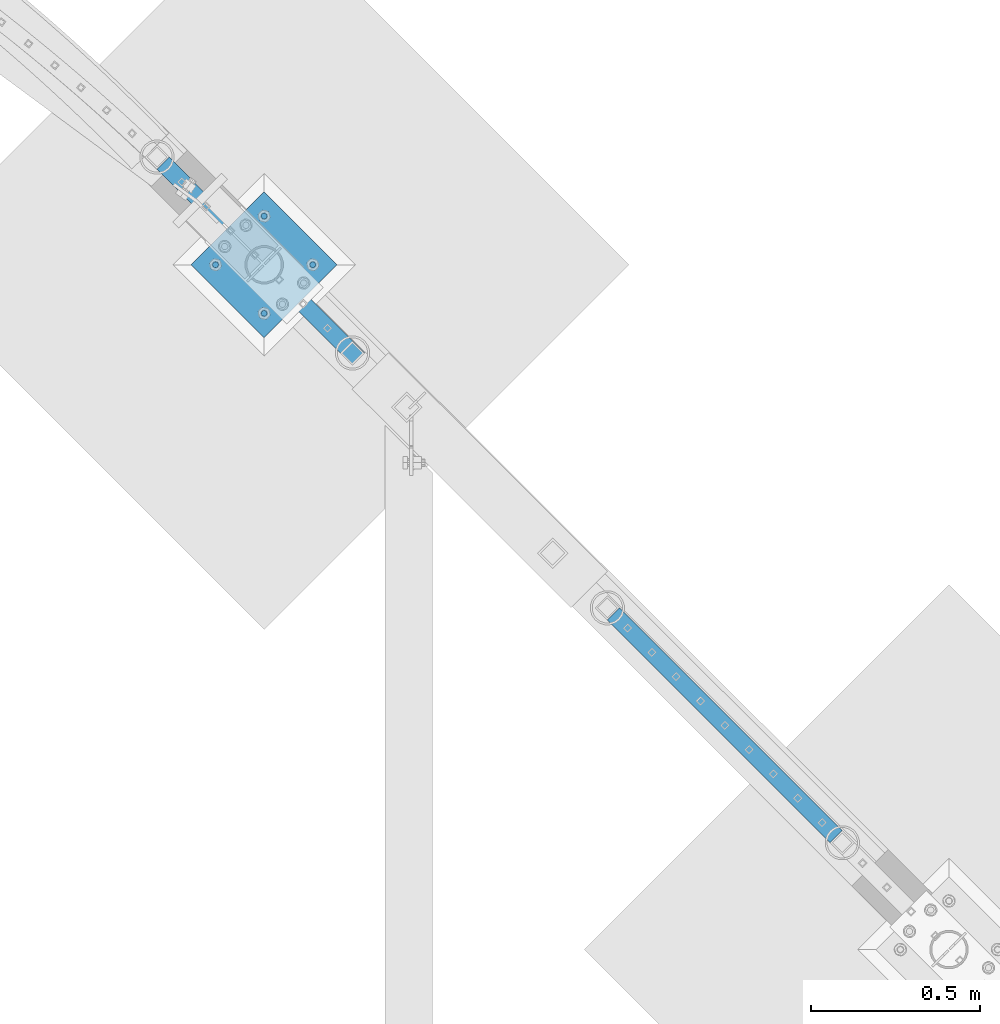
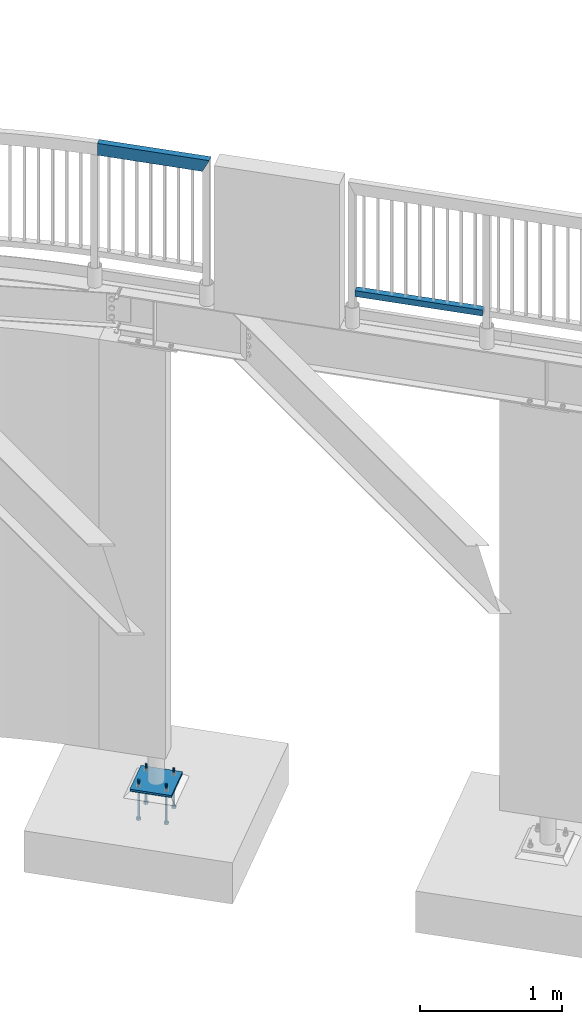
# One storey, part 452 of 975: 8 beams.
"""IFC2X3 building model written with IfcOpenShell, lengths in millimetres."""

from ifc_helpers import new_model, si_unit, frame, origin_with_axes, place, context, subcontext, project, spatial, faceted_brep, material, type_object, element, save


model = new_model("IFC2X3")

# Units and contexts
model_context = context("Model", 3, precision=1e-05, world=origin_with_axes())
body_context = subcontext(model_context, "Body", "Model", "MODEL_VIEW")
ifc_project = project(units=[si_unit("LENGTHUNIT", "METRE", prefix="MILLI"), si_unit("AREAUNIT", "SQUARE_METRE"), si_unit("VOLUMEUNIT", "CUBIC_METRE"), si_unit("MASSUNIT", "GRAM", prefix="KILO"), si_unit("TIMEUNIT", "SECOND"), si_unit("PLANEANGLEUNIT", "RADIAN"), si_unit("SOLIDANGLEUNIT", "STERADIAN"), si_unit("THERMODYNAMICTEMPERATUREUNIT", "DEGREE_CELSIUS"), si_unit("LUMINOUSINTENSITYUNIT", "LUMEN")], contexts=[model_context])

# Site, building, storey
site_placement = place(None, origin_with_axes())
site = spatial("IfcSite", under=ifc_project, at=site_placement, CompositionType="ELEMENT")
building_placement = place(site_placement, origin_with_axes())
building = spatial("IfcBuilding", under=site, at=building_placement, Name="Undefined", CompositionType="ELEMENT")
storey_placement = place(building_placement, origin_with_axes())
storey = spatial("IfcBuildingStorey", under=building, at=storey_placement, Name="Undefined", CompositionType="ELEMENT", Elevation=0.0)

# Beams
ifc_material_1 = material()
beam_type_1 = type_object("IfcBeamType", Name="HSS2X2X.188_TUBES", PredefinedType="NOTDEFINED")
beam_1_placement = place(storey_placement, frame((22439.8337126223, 26194.8377274758, 4229.09999851784), z_axis=(-0.70706737708869, -0.707146183088702, 0.0), x_axis=(-0.707146183088701, 0.707067377088692, 1.9999997400896e-09)))
element("IfcBeam", 1, at=beam_1_placement, inside=storey, type_object=beam_type_1, material=ifc_material_1, Name="HANDRAIL", ObjectType="HSS2X2X.188_TUBES", context=body_context, shape_type="Brep", body=[
    faceted_brep([(25.3980770247526, 20.6375000000007, -20.6375000000553), (25.3981117216435, -20.6374999999998, -20.6375000000553), (956.733660036939, -20.6374999999807, -20.6375000008629), (956.733659954443, 20.6375000000198, -20.6375000008702), (25.4004117403574, -20.6374999999998, 20.6375000000116), (956.735960055649, -20.6374999999807, 20.637499999204), (25.4003770434665, 20.6375000000007, 20.6375000000116), (956.735959973155, 20.6375000000198, 20.6374999991967), (25.3978076344952, 25.4000000000005, -25.4000000000669), (25.4006384267554, 25.4000000000005, 25.4000000000087), (956.736225350408, 25.4000000000196, 25.3999999992011), (956.733394558152, 25.4000000000206, -25.4000000008746), (25.4006811306149, -25.3999999999987, 25.4000000000233), (956.736225451941, -25.3999999999796, 25.3999999992084), (25.3978503383546, -25.3999999999987, -25.4000000000597), (956.733394659682, -25.3999999999796, -25.4000000008673)], [[[0, 1, 2, 3]], [[1, 4, 5, 2]], [[4, 6, 7, 5]], [[6, 0, 3, 7]], [[8, 9, 10, 11]], [[9, 12, 13, 10]], [[12, 14, 15, 13]], [[14, 8, 11, 15]], [[13, 15, 11, 10], [5, 7, 3, 2]], [[14, 12, 9, 8], [6, 4, 1, 0]]]),
])
beam_type_2 = type_object("IfcBeamType", Name="HSS2X4X.188_TUBES", PredefinedType="NOTDEFINED")
beam_2_placement = place(storey_placement, frame((20432.5594674233, 28203.6220750754, 5130.8), z_axis=(0.0, 0.0, 1.0), x_axis=(0.706118042881266, -0.708094138880933, 0.0)))
element("IfcBeam", 2, at=beam_2_placement, inside=storey, type_object=beam_type_2, material=ifc_material_1, Name="GUARDRAIL", ObjectType="HSS2X4X.188_TUBES", context=body_context, shape_type="Brep", body=[
    faceted_brep([(-1.09139364212751e-11, 20.6375000000262, -46.0375000000004), (1.63709046319127e-11, -20.6375000000262, -46.0375000000004), (769.454988216639, -20.637499999415, -46.0375000000004), (769.454988216639, 20.6375000006374, -46.0375000000004), (1.63709046319127e-11, -20.6375000000262, 46.0375000000004), (815.556772021477, -20.6374999993714, 46.0375000000004), (-1.09139364212751e-11, 20.6375000000262, 46.0375000000004), (815.556772021479, 20.637500000681, 46.0375000000004), (-1.81898940354586e-11, 25.4000000000378, -50.8000000000002), (1.10786999130141e-07, 25.4000000000015, 50.8000000000011), (817.941347045869, 25.4000000006854, 50.8000000000002), (767.070413192252, 25.400000000649, -50.8000000000002), (1.36218801571886e-07, -25.4000000000015, 50.8000000000011), (817.941347045866, -25.3999999993757, 50.8000000000002), (2.36468622460961e-11, -25.4000000000306, -50.8000000000002), (767.070413192252, -25.3999999994194, -50.8000000000002)], [[[0, 1, 2, 3]], [[1, 4, 5, 2]], [[4, 6, 7, 5]], [[6, 0, 3, 7]], [[8, 9, 10, 11]], [[9, 12, 13, 10]], [[12, 14, 15, 13]], [[14, 8, 11, 15]], [[13, 15, 11, 10], [5, 7, 3, 2]], [[14, 12, 9, 8], [6, 4, 1, 0]]]),
])
ifc_material_2 = material(Name="STEEL/A36")
beam_type_3 = type_object("IfcBeamType", PredefinedType="NOTDEFINED")
beam_3_placement = place(storey_placement, frame((20838.9255734522, 27795.7244265478, -257.175000000002), z_axis=(-0.707106781186548, -0.707106781186548, 0.0), x_axis=(-0.707106781186601, 0.707106781186494, 2.36468622460961e-14)))
element("IfcBeam", 3, at=beam_3_placement, inside=storey, type_object=beam_type_3, material=ifc_material_2, Name="PLATE", context=body_context, shape_type="Brep", body=[
    faceted_brep([(0.0, 9.52499999999964, -152.4), (0.0, 9.52499999999964, 152.4), (304.799999999152, 9.52499999999964, 152.4), (304.799999999152, 9.52499999999964, -152.4), (0.0, -9.52499999999964, 152.4), (304.799999999152, -9.52499999999964, 152.4), (0.0, -9.52499999999964, -152.4), (304.799999999152, -9.52499999999964, -152.4)], [[[0, 1, 2, 3]], [[1, 4, 5, 2]], [[4, 6, 7, 5]], [[6, 0, 3, 7]], [[5, 7, 3, 2]], [[6, 4, 1, 0]]]),
])
ifc_material_3 = material(Name="STEEL/F1554-36")
beam_type_4 = type_object("IfcBeamType", PredefinedType="NOTDEFINED")
beam_4_placement = place(storey_placement, frame((20874.8465946999, 27903.487501079, -304.799999999999), z_axis=(-0.707106781186601, 0.707106781186494, 2.36468622460961e-14), x_axis=(0.0, 0.0, -1.0)))
element("IfcBeam", 4, at=beam_4_placement, inside=storey, type_object=beam_type_4, material=ifc_material_3, Name="HEADED_ANCHOR_BOLT", context=body_context, shape_type="Brep", body=[
    faceted_brep([(209.543749999999, -9.13000011446275, 15.8100004196049), (209.543749999999, -18.2600002288382, 4.72937244921923e-11), (228.593749999998, -18.2600002288382, 4.72937244921923e-11), (228.593749999998, -9.13000011446275, 15.8100004196049), (209.543749999999, 9.13000011438271, 15.8100004195576), (228.593749999998, 9.13000011438271, 15.8100004195576), (209.543749999999, 18.2600002288382, -4.72937244921923e-11), (228.593749999998, 18.2600002288382, -4.72937244921923e-11), (209.543749999999, 9.13000011446275, -15.8100004196049), (228.593749999998, 9.13000011446275, -15.8100004196049), (209.543749999999, -9.13000011438271, -15.8100004195576), (228.593749999998, -9.13000011438271, -15.8100004195576), (209.543749999999, -4.4776800552936, 9.29799844178979), (209.543749999999, -8.068500660469, 6.43441456491473), (209.543749999999, -10.0612557561763, 2.2964159705416), (209.543749999999, -10.0612557561617, -2.29641597048976), (209.543749999999, -8.0685006604399, -6.4344145648729), (209.543749999999, -4.47768005524995, -9.29799844176705), (209.543749999999, 2.91038304567337e-11, -10.3199996948015), (209.543749999999, 4.4776800552936, -9.29799844178979), (209.543749999999, 8.068500660469, -6.43441456491473), (209.543749999999, 10.0612557561763, -2.2964159705416), (209.543749999999, 10.0612557561617, 2.29641597048976), (209.543749999999, 8.0685006604399, 6.4344145648729), (209.543749999999, 4.47768005524995, 9.29799844176705), (209.543749999999, -2.91038304567337e-11, 10.3199996948015), (228.593749999998, -2.91038304567337e-11, 10.3199996948015), (228.593749999998, -4.4776800552936, 9.29799844178979), (228.593749999998, -8.068500660469, 6.43441456491473), (228.593749999998, -10.0612557561763, 2.2964159705416), (228.593749999998, -10.0612557561617, -2.29641597048976), (228.593749999998, -8.0685006604399, -6.4344145648729), (228.593749999998, -4.47768005524995, -9.29799844176705), (228.593749999998, 2.91038304567337e-11, -10.3199996948015), (228.593749999998, 4.4776800552936, -9.29799844178979), (228.593749999998, 8.068500660469, -6.43441456491473), (228.593749999998, 10.0612557561763, -2.2964159705416), (228.593749999998, 10.0612557561617, 2.29641597048976), (228.593749999998, 8.0685006604399, 6.4344145648729), (228.593749999998, 4.47768005524995, 9.29799844176705), (0.0, -6.73519209080223, 6.73519209080186), (0.0, -9.52499999999964, 0.0), (228.6, -9.52500000000146, 0.0), (228.6, -6.73519209080405, 6.73519209080223), (-9.87109982941227e-13, -1.20792265079217e-13, 9.52499961853027), (228.6, 0.0, 9.52499999999964), (0.0, 6.73519209080223, 6.73519209080186), (228.6, 6.73519209080405, 6.73519209080223), (0.0, 9.52499999999964, 0.0), (228.6, 9.52500000000146, 0.0), (0.0, 6.73519209080223, -6.73519209080186), (228.6, 6.73519209080405, -6.73519209080223), (2.95075507493764e-12, -1.20792265079217e-13, -9.52499961853027), (228.6, 0.0, -9.52499999999964), (-114.297914995421, -6.36396103067818, 6.36396103068091), (-114.297914995421, -2.18278728425503e-11, 8.99999999997999), (-114.297914995421, 6.36396103064908, 6.36396103064817), (-114.297914995421, 8.99999999997817, -2.27373675443232e-11), (-114.297914995421, 6.36396103067818, -6.36396103068091), (-114.297914995421, 2.18278728425503e-11, -8.99999999997999), (-114.297914995421, -6.36396103064908, -6.36396103064817), (-114.297914995421, -8.99999999997817, 2.27373675443232e-11), (0.0149743263646087, 6.36396103067818, -6.36396103067909), (0.0149743263646087, 0.0, -9.0), (0.0149743263646087, -6.36396103067818, -6.36396103067909), (0.0149743263987148, -8.9999995411581, -1.00796984270346e-06), (0.0149743263646087, -6.36396103067818, 6.36396103067909), (0.0149743263646087, 0.0, 9.0), (0.0149743263646087, 6.36396103067818, 6.36396103067909), (0.0149743263987148, 9.0000004588419, -1.00796984270346e-06), (0.0, -6.73519209080223, -6.73519209080186), (228.6, -6.73519209080405, -6.73519209080223)], [[[0, 1, 2, 3]], [[4, 0, 3, 5]], [[6, 4, 5, 7]], [[8, 6, 7, 9]], [[10, 8, 9, 11]], [[0, 4, 6, 8, 10, 1], [12, 13, 14, 15, 16, 17, 18, 19, 20, 21, 22, 23, 24, 25]], [[12, 25, 26, 27]], [[13, 12, 27, 28]], [[14, 13, 28, 29]], [[15, 14, 29, 30]], [[16, 15, 30, 31]], [[17, 16, 31, 32]], [[18, 17, 32, 33]], [[19, 18, 33, 34]], [[20, 19, 34, 35]], [[21, 20, 35, 36]], [[22, 21, 36, 37]], [[23, 22, 37, 38]], [[24, 23, 38, 39]], [[25, 24, 39, 26]], [[9, 7, 5, 3, 2, 11], [38, 37, 36, 35, 34, 33, 32, 31, 30, 29, 28, 27, 26, 39]], [[1, 10, 11, 2]], [[40, 41, 42, 43]], [[44, 40, 43, 45]], [[46, 44, 45, 47]], [[48, 46, 47, 49]], [[50, 48, 49, 51]], [[52, 50, 51, 53]], [[54, 55, 56, 57, 58, 59, 60, 61]], [[59, 58, 62, 63]], [[60, 59, 63, 64]], [[61, 60, 64, 65]], [[54, 61, 65, 66]], [[55, 54, 66, 67]], [[56, 55, 67, 68]], [[57, 56, 68, 69]], [[58, 57, 69, 62]], [[40, 44, 46, 48, 50, 52, 70, 41], [68, 67, 66, 65, 64, 63, 62, 69]], [[41, 70, 71, 42]], [[53, 51, 49, 47, 45, 43, 42, 71]], [[70, 52, 53, 71]]]),
])
beam_5_placement = place(storey_placement, frame((20731.162498921, 27759.8034053001, -304.799999999999), z_axis=(-0.707106781186601, 0.707106781186494, 2.36468622460961e-14), x_axis=(0.0, 0.0, -1.0)))
element("IfcBeam", 5, at=beam_5_placement, inside=storey, type_object=beam_type_4, material=ifc_material_3, Name="HEADED_ANCHOR_BOLT", context=body_context, shape_type="Brep", body=[
    faceted_brep([(209.543749999999, 9.13000011446275, -15.8100004196049), (209.543749999999, 18.2600002288382, -4.72937244921923e-11), (228.593749999998, 18.2600002288382, -4.72937244921923e-11), (228.593749999998, 9.13000011446275, -15.8100004196049), (209.543749999999, -9.13000011438271, -15.8100004195576), (228.593749999998, -9.13000011438271, -15.8100004195576), (209.543749999999, -18.2600002288382, 4.72937244921923e-11), (228.593749999998, -18.2600002288382, 4.72937244921923e-11), (209.543749999999, -9.13000011446275, 15.8100004196049), (228.593749999998, -9.13000011446275, 15.8100004196049), (209.543749999999, 9.13000011438271, 15.8100004195576), (228.593749999998, 9.13000011438271, 15.8100004195576), (209.543749999999, -4.4776800552936, 9.29799844178979), (209.543749999999, -8.068500660469, 6.43441456491473), (209.543749999999, -10.0612557561763, 2.2964159705416), (209.543749999999, -10.0612557561617, -2.29641597048976), (209.543749999999, -8.0685006604399, -6.4344145648729), (209.543749999999, -4.47768005524995, -9.29799844176705), (209.543749999999, 2.91038304567337e-11, -10.3199996948015), (209.543749999999, 4.4776800552936, -9.29799844178979), (209.543749999999, 8.068500660469, -6.43441456491473), (209.543749999999, 10.0612557561763, -2.2964159705416), (209.543749999999, 10.0612557561617, 2.29641597048976), (209.543749999999, 8.0685006604399, 6.4344145648729), (209.543749999999, 4.47768005524995, 9.29799844176705), (209.543749999999, -2.91038304567337e-11, 10.3199996948015), (228.593749999998, 2.91038304567337e-11, -10.3199996948015), (228.593749999998, 4.4776800552936, -9.29799844178979), (228.593749999998, 8.068500660469, -6.43441456491473), (228.593749999998, 10.0612557561763, -2.2964159705416), (228.593749999998, 10.0612557561617, 2.29641597048976), (228.593749999998, 8.0685006604399, 6.4344145648729), (228.593749999998, 4.47768005524995, 9.29799844176705), (228.593749999998, -2.91038304567337e-11, 10.3199996948015), (228.593749999998, -4.4776800552936, 9.29799844178979), (228.593749999998, -8.068500660469, 6.43441456491473), (228.593749999998, -10.0612557561763, 2.2964159705416), (228.593749999998, -10.0612557561617, -2.29641597048976), (228.593749999998, -8.0685006604399, -6.4344145648729), (228.593749999998, -4.47768005524995, -9.29799844176705), (0.0, -6.73519209080223, 6.73519209080186), (0.0, -9.52499999999964, 0.0), (228.6, -9.52500000000146, 0.0), (228.6, -6.73519209080405, 6.73519209080223), (-9.87109982941227e-13, -1.20792265079217e-13, 9.52499961853027), (228.6, 0.0, 9.52499999999964), (0.0, 6.73519209080223, 6.73519209080186), (228.6, 6.73519209080405, 6.73519209080223), (0.0, 9.52499999999964, 0.0), (228.6, 9.52500000000146, 0.0), (0.0, 6.73519209080223, -6.73519209080186), (228.6, 6.73519209080405, -6.73519209080223), (2.95075507493764e-12, -1.20792265079217e-13, -9.52499961853027), (228.6, 0.0, -9.52499999999964), (-114.297914995421, -6.36396103067818, 6.36396103068091), (-114.297914995421, -2.18278728425503e-11, 8.99999999997999), (-114.297914995421, 6.36396103064908, 6.36396103064817), (-114.297914995421, 8.99999999997817, -2.27373675443232e-11), (-114.297914995421, 6.36396103067818, -6.36396103068091), (-114.297914995421, 2.18278728425503e-11, -8.99999999997999), (-114.297914995421, -6.36396103064908, -6.36396103064817), (-114.297914995421, -8.99999999997817, 2.27373675443232e-11), (0.0149743263646087, 6.36396103067818, -6.36396103067909), (0.0149743263646087, 0.0, -9.0), (0.0149743263646087, -6.36396103067818, -6.36396103067909), (0.0149743263987148, -8.9999995411581, -1.00796984270346e-06), (0.0149743263646087, -6.36396103067818, 6.36396103067909), (0.0149743263646087, 0.0, 9.0), (0.0149743263646087, 6.36396103067818, 6.36396103067909), (0.0149743263987148, 9.0000004588419, -1.00796984270346e-06), (0.0, -6.73519209080223, -6.73519209080186), (228.6, -6.73519209080405, -6.73519209080223)], [[[0, 1, 2, 3]], [[4, 0, 3, 5]], [[6, 4, 5, 7]], [[8, 6, 7, 9]], [[10, 8, 9, 11]], [[8, 10, 1, 0, 4, 6], [12, 13, 14, 15, 16, 17, 18, 19, 20, 21, 22, 23, 24, 25]], [[19, 18, 26, 27]], [[20, 19, 27, 28]], [[21, 20, 28, 29]], [[22, 21, 29, 30]], [[23, 22, 30, 31]], [[24, 23, 31, 32]], [[25, 24, 32, 33]], [[12, 25, 33, 34]], [[13, 12, 34, 35]], [[14, 13, 35, 36]], [[15, 14, 36, 37]], [[16, 15, 37, 38]], [[17, 16, 38, 39]], [[18, 17, 39, 26]], [[3, 2, 11, 9, 7, 5], [31, 30, 29, 28, 27, 26, 39, 38, 37, 36, 35, 34, 33, 32]], [[1, 10, 11, 2]], [[40, 41, 42, 43]], [[44, 40, 43, 45]], [[46, 44, 45, 47]], [[48, 46, 47, 49]], [[50, 48, 49, 51]], [[52, 50, 51, 53]], [[54, 55, 56, 57, 58, 59, 60, 61]], [[59, 58, 62, 63]], [[60, 59, 63, 64]], [[61, 60, 64, 65]], [[54, 61, 65, 66]], [[55, 54, 66, 67]], [[56, 55, 67, 68]], [[57, 56, 68, 69]], [[58, 57, 69, 62]], [[40, 44, 46, 48, 50, 52, 70, 41], [68, 67, 66, 65, 64, 63, 62, 69]], [[41, 70, 71, 42]], [[53, 51, 49, 47, 45, 43, 42, 71]], [[70, 52, 53, 71]]]),
])
beam_6_placement = place(storey_placement, frame((20587.4784031422, 27903.487501079, -304.799999999999), z_axis=(-0.707106781186601, 0.707106781186494, 2.36468622460961e-14), x_axis=(0.0, 0.0, -1.0)))
element("IfcBeam", 6, at=beam_6_placement, inside=storey, type_object=beam_type_4, material=ifc_material_3, Name="HEADED_ANCHOR_BOLT", context=body_context, shape_type="Brep", body=[
    faceted_brep([(209.543749999999, 9.13000011446275, -15.8100004196049), (209.543749999999, 18.2600002288382, -4.72937244921923e-11), (228.593749999998, 18.2600002288382, -4.72937244921923e-11), (228.593749999998, 9.13000011446275, -15.8100004196049), (209.543749999999, -9.13000011438271, -15.8100004195576), (228.593749999998, -9.13000011438271, -15.8100004195576), (209.543749999999, -18.2600002288382, 4.72937244921923e-11), (228.593749999998, -18.2600002288382, 4.72937244921923e-11), (209.543749999999, -9.13000011446275, 15.8100004196049), (228.593749999998, -9.13000011446275, 15.8100004196049), (209.543749999999, 9.13000011438271, 15.8100004195576), (228.593749999998, 9.13000011438271, 15.8100004195576), (209.543749999999, -4.4776800552936, 9.29799844178979), (209.543749999999, -8.068500660469, 6.43441456491473), (209.543749999999, -10.0612557561763, 2.2964159705416), (209.543749999999, -10.0612557561617, -2.29641597048976), (209.543749999999, -8.0685006604399, -6.4344145648729), (209.543749999999, -4.47768005524995, -9.29799844176705), (209.543749999999, 2.91038304567337e-11, -10.3199996948015), (209.543749999999, 4.4776800552936, -9.29799844178979), (209.543749999999, 8.068500660469, -6.43441456491473), (209.543749999999, 10.0612557561763, -2.2964159705416), (209.543749999999, 10.0612557561617, 2.29641597048976), (209.543749999999, 8.0685006604399, 6.4344145648729), (209.543749999999, 4.47768005524995, 9.29799844176705), (209.543749999999, -2.91038304567337e-11, 10.3199996948015), (228.593749999998, 2.91038304567337e-11, -10.3199996948015), (228.593749999998, 4.4776800552936, -9.29799844178979), (228.593749999998, 8.068500660469, -6.43441456491473), (228.593749999998, 10.0612557561763, -2.2964159705416), (228.593749999998, 10.0612557561617, 2.29641597048976), (228.593749999998, 8.0685006604399, 6.4344145648729), (228.593749999998, 4.47768005524995, 9.29799844176705), (228.593749999998, -2.91038304567337e-11, 10.3199996948015), (228.593749999998, -4.4776800552936, 9.29799844178979), (228.593749999998, -8.068500660469, 6.43441456491473), (228.593749999998, -10.0612557561763, 2.2964159705416), (228.593749999998, -10.0612557561617, -2.29641597048976), (228.593749999998, -8.0685006604399, -6.4344145648729), (228.593749999998, -4.47768005524995, -9.29799844176705), (0.0, -6.73519209080223, 6.73519209080186), (0.0, -9.52499999999964, 0.0), (228.6, -9.52500000000146, 0.0), (228.6, -6.73519209080405, 6.73519209080223), (-9.87109982941227e-13, -1.20792265079217e-13, 9.52499961853027), (228.6, 0.0, 9.52499999999964), (0.0, 6.73519209080223, 6.73519209080186), (228.6, 6.73519209080405, 6.73519209080223), (0.0, 9.52499999999964, 0.0), (228.6, 9.52500000000146, 0.0), (0.0, 6.73519209080223, -6.73519209080186), (228.6, 6.73519209080405, -6.73519209080223), (2.95075507493764e-12, -1.20792265079217e-13, -9.52499961853027), (228.6, 0.0, -9.52499999999964), (-114.297914995421, -6.36396103067818, 6.36396103068091), (-114.297914995421, -2.18278728425503e-11, 8.99999999997999), (-114.297914995421, 6.36396103064908, 6.36396103064817), (-114.297914995421, 8.99999999997817, -2.27373675443232e-11), (-114.297914995421, 6.36396103067818, -6.36396103068091), (-114.297914995421, 2.18278728425503e-11, -8.99999999997999), (-114.297914995421, -6.36396103064908, -6.36396103064817), (-114.297914995421, -8.99999999997817, 2.27373675443232e-11), (0.0149743263646087, 6.36396103067818, -6.36396103067909), (0.0149743263646087, 0.0, -9.0), (0.0149743263646087, -6.36396103067818, -6.36396103067909), (0.0149743263987148, -8.9999995411581, -1.00796984270346e-06), (0.0149743263646087, -6.36396103067818, 6.36396103067909), (0.0149743263646087, 0.0, 9.0), (0.0149743263646087, 6.36396103067818, 6.36396103067909), (0.0149743263987148, 9.0000004588419, -1.00796984270346e-06), (0.0, -6.73519209080223, -6.73519209080186), (228.6, -6.73519209080405, -6.73519209080223)], [[[0, 1, 2, 3]], [[4, 0, 3, 5]], [[6, 4, 5, 7]], [[8, 6, 7, 9]], [[10, 8, 9, 11]], [[8, 10, 1, 0, 4, 6], [12, 13, 14, 15, 16, 17, 18, 19, 20, 21, 22, 23, 24, 25]], [[19, 18, 26, 27]], [[20, 19, 27, 28]], [[21, 20, 28, 29]], [[22, 21, 29, 30]], [[23, 22, 30, 31]], [[24, 23, 31, 32]], [[25, 24, 32, 33]], [[12, 25, 33, 34]], [[13, 12, 34, 35]], [[14, 13, 35, 36]], [[15, 14, 36, 37]], [[16, 15, 37, 38]], [[17, 16, 38, 39]], [[18, 17, 39, 26]], [[3, 2, 11, 9, 7, 5], [31, 30, 29, 28, 27, 26, 39, 38, 37, 36, 35, 34, 33, 32]], [[1, 10, 11, 2]], [[40, 41, 42, 43]], [[44, 40, 43, 45]], [[46, 44, 45, 47]], [[48, 46, 47, 49]], [[50, 48, 49, 51]], [[52, 50, 51, 53]], [[54, 55, 56, 57, 58, 59, 60, 61]], [[59, 58, 62, 63]], [[60, 59, 63, 64]], [[61, 60, 64, 65]], [[54, 61, 65, 66]], [[55, 54, 66, 67]], [[56, 55, 67, 68]], [[57, 56, 68, 69]], [[58, 57, 69, 62]], [[40, 44, 46, 48, 50, 52, 70, 41], [68, 67, 66, 65, 64, 63, 62, 69]], [[41, 70, 71, 42]], [[53, 51, 49, 47, 45, 43, 42, 71]], [[70, 52, 53, 71]]]),
])
beam_7_placement = place(storey_placement, frame((20731.162498921, 28047.1715968578, -304.799999999999), z_axis=(-0.707106781186601, 0.707106781186494, 2.36468622460961e-14), x_axis=(0.0, 0.0, -1.0)))
element("IfcBeam", 7, at=beam_7_placement, inside=storey, type_object=beam_type_4, material=ifc_material_3, Name="HEADED_ANCHOR_BOLT", context=body_context, shape_type="Brep", body=[
    faceted_brep([(209.543749999999, -9.13000011446275, 15.8100004196049), (209.543749999999, -18.2600002288382, 4.72937244921923e-11), (228.593749999998, -18.2600002288382, 4.72937244921923e-11), (228.593749999998, -9.13000011446275, 15.8100004196049), (209.543749999999, 9.13000011438271, 15.8100004195576), (228.593749999998, 9.13000011438271, 15.8100004195576), (209.543749999999, 18.2600002288382, -4.72937244921923e-11), (228.593749999998, 18.2600002288382, -4.72937244921923e-11), (209.543749999999, 9.13000011446275, -15.8100004196049), (228.593749999998, 9.13000011446275, -15.8100004196049), (209.543749999999, -9.13000011438271, -15.8100004195576), (228.593749999998, -9.13000011438271, -15.8100004195576), (209.543749999999, -4.4776800552936, 9.29799844178979), (209.543749999999, -8.068500660469, 6.43441456491473), (209.543749999999, -10.0612557561763, 2.2964159705416), (209.543749999999, -10.0612557561617, -2.29641597048976), (209.543749999999, -8.0685006604399, -6.4344145648729), (209.543749999999, -4.47768005524995, -9.29799844176705), (209.543749999999, 2.91038304567337e-11, -10.3199996948015), (209.543749999999, 4.4776800552936, -9.29799844178979), (209.543749999999, 8.068500660469, -6.43441456491473), (209.543749999999, 10.0612557561763, -2.2964159705416), (209.543749999999, 10.0612557561617, 2.29641597048976), (209.543749999999, 8.0685006604399, 6.4344145648729), (209.543749999999, 4.47768005524995, 9.29799844176705), (209.543749999999, -2.91038304567337e-11, 10.3199996948015), (228.593749999998, -2.91038304567337e-11, 10.3199996948015), (228.593749999998, -4.4776800552936, 9.29799844178979), (228.593749999998, -8.068500660469, 6.43441456491473), (228.593749999998, -10.0612557561763, 2.2964159705416), (228.593749999998, -10.0612557561617, -2.29641597048976), (228.593749999998, -8.0685006604399, -6.4344145648729), (228.593749999998, -4.47768005524995, -9.29799844176705), (228.593749999998, 2.91038304567337e-11, -10.3199996948015), (228.593749999998, 4.4776800552936, -9.29799844178979), (228.593749999998, 8.068500660469, -6.43441456491473), (228.593749999998, 10.0612557561763, -2.2964159705416), (228.593749999998, 10.0612557561617, 2.29641597048976), (228.593749999998, 8.0685006604399, 6.4344145648729), (228.593749999998, 4.47768005524995, 9.29799844176705), (0.0, -6.73519209080223, 6.73519209080186), (0.0, -9.52499999999964, 0.0), (228.6, -9.52500000000146, 0.0), (228.6, -6.73519209080405, 6.73519209080223), (-9.87109982941227e-13, -1.20792265079217e-13, 9.52499961853027), (228.6, 0.0, 9.52499999999964), (0.0, 6.73519209080223, 6.73519209080186), (228.6, 6.73519209080405, 6.73519209080223), (0.0, 9.52499999999964, 0.0), (228.6, 9.52500000000146, 0.0), (0.0, 6.73519209080223, -6.73519209080186), (228.6, 6.73519209080405, -6.73519209080223), (2.95075507493764e-12, -1.20792265079217e-13, -9.52499961853027), (228.6, 0.0, -9.52499999999964), (-114.297914995421, -6.36396103067818, 6.36396103068091), (-114.297914995421, -2.18278728425503e-11, 8.99999999997999), (-114.297914995421, 6.36396103064908, 6.36396103064817), (-114.297914995421, 8.99999999997817, -2.27373675443232e-11), (-114.297914995421, 6.36396103067818, -6.36396103068091), (-114.297914995421, 2.18278728425503e-11, -8.99999999997999), (-114.297914995421, -6.36396103064908, -6.36396103064817), (-114.297914995421, -8.99999999997817, 2.27373675443232e-11), (0.0149743263646087, 6.36396103067818, -6.36396103067909), (0.0149743263646087, 0.0, -9.0), (0.0149743263646087, -6.36396103067818, -6.36396103067909), (0.0149743263987148, -8.9999995411581, -1.00796984270346e-06), (0.0149743263646087, -6.36396103067818, 6.36396103067909), (0.0149743263646087, 0.0, 9.0), (0.0149743263646087, 6.36396103067818, 6.36396103067909), (0.0149743263987148, 9.0000004588419, -1.00796984270346e-06), (0.0, -6.73519209080223, -6.73519209080186), (228.6, -6.73519209080405, -6.73519209080223)], [[[0, 1, 2, 3]], [[4, 0, 3, 5]], [[6, 4, 5, 7]], [[8, 6, 7, 9]], [[10, 8, 9, 11]], [[0, 4, 6, 8, 10, 1], [12, 13, 14, 15, 16, 17, 18, 19, 20, 21, 22, 23, 24, 25]], [[12, 25, 26, 27]], [[13, 12, 27, 28]], [[14, 13, 28, 29]], [[15, 14, 29, 30]], [[16, 15, 30, 31]], [[17, 16, 31, 32]], [[18, 17, 32, 33]], [[19, 18, 33, 34]], [[20, 19, 34, 35]], [[21, 20, 35, 36]], [[22, 21, 36, 37]], [[23, 22, 37, 38]], [[24, 23, 38, 39]], [[25, 24, 39, 26]], [[9, 7, 5, 3, 2, 11], [38, 37, 36, 35, 34, 33, 32, 31, 30, 29, 28, 27, 26, 39]], [[1, 10, 11, 2]], [[40, 41, 42, 43]], [[44, 40, 43, 45]], [[46, 44, 45, 47]], [[48, 46, 47, 49]], [[50, 48, 49, 51]], [[52, 50, 51, 53]], [[54, 55, 56, 57, 58, 59, 60, 61]], [[59, 58, 62, 63]], [[60, 59, 63, 64]], [[61, 60, 64, 65]], [[54, 61, 65, 66]], [[55, 54, 66, 67]], [[56, 55, 67, 68]], [[57, 56, 68, 69]], [[58, 57, 69, 62]], [[40, 44, 46, 48, 50, 52, 70, 41], [68, 67, 66, 65, 64, 63, 62, 69]], [[41, 70, 71, 42]], [[53, 51, 49, 47, 45, 43, 42, 71]], [[70, 52, 53, 71]]]),
])
beam_type_5 = type_object("IfcBeamType", PredefinedType="NOTDEFINED")
beam_8_placement = place(storey_placement, frame((20838.9255734522, 27795.7244265478, -265.112500000001), z_axis=(-0.707106781186548, -0.707106781186548, 0.0), x_axis=(-0.707106781186601, 0.707106781186494, 2.36468622460961e-14)))
element("IfcBeam", 8, at=beam_8_placement, inside=storey, type_object=beam_type_5, material=ifc_material_2, Name="TEMPLATE", context=body_context, shape_type="Brep", body=[
    faceted_brep([(0.0, 1.58750000000009, -152.4), (0.0, 1.58750000000009, 152.4), (304.799999999153, 1.58750000000001, 152.400000000001), (304.799999999153, 1.58750000000001, -152.400000000001), (0.0, -1.58750000000009, 152.4), (304.799999999153, -1.58750000000001, 152.400000000001), (0.0, -1.58750000000009, -152.4), (304.799999999153, -1.58750000000001, -152.400000000001)], [[[0, 1, 2, 3]], [[1, 4, 5, 2]], [[4, 6, 7, 5]], [[6, 0, 3, 7]], [[5, 7, 3, 2]], [[6, 4, 1, 0]]]),
])

save(model, "model.ifc")
